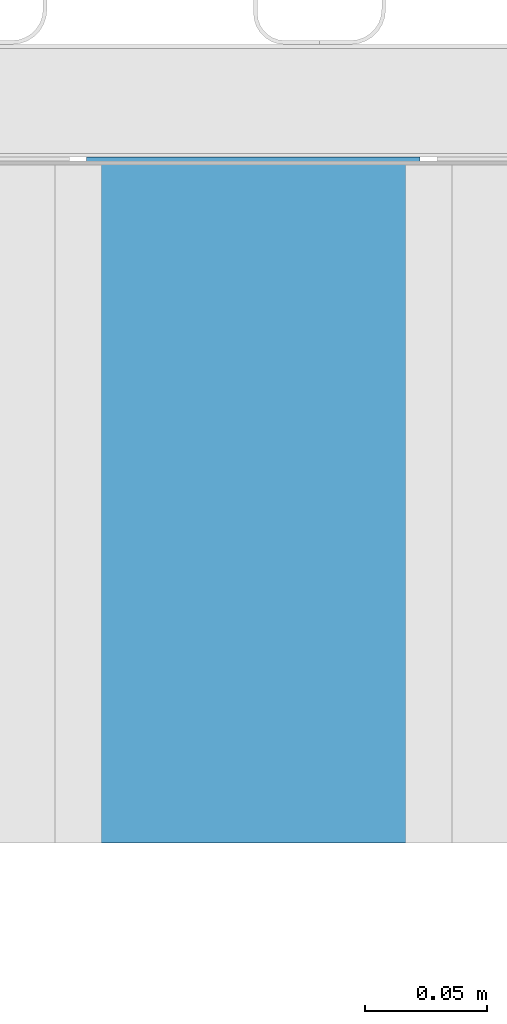
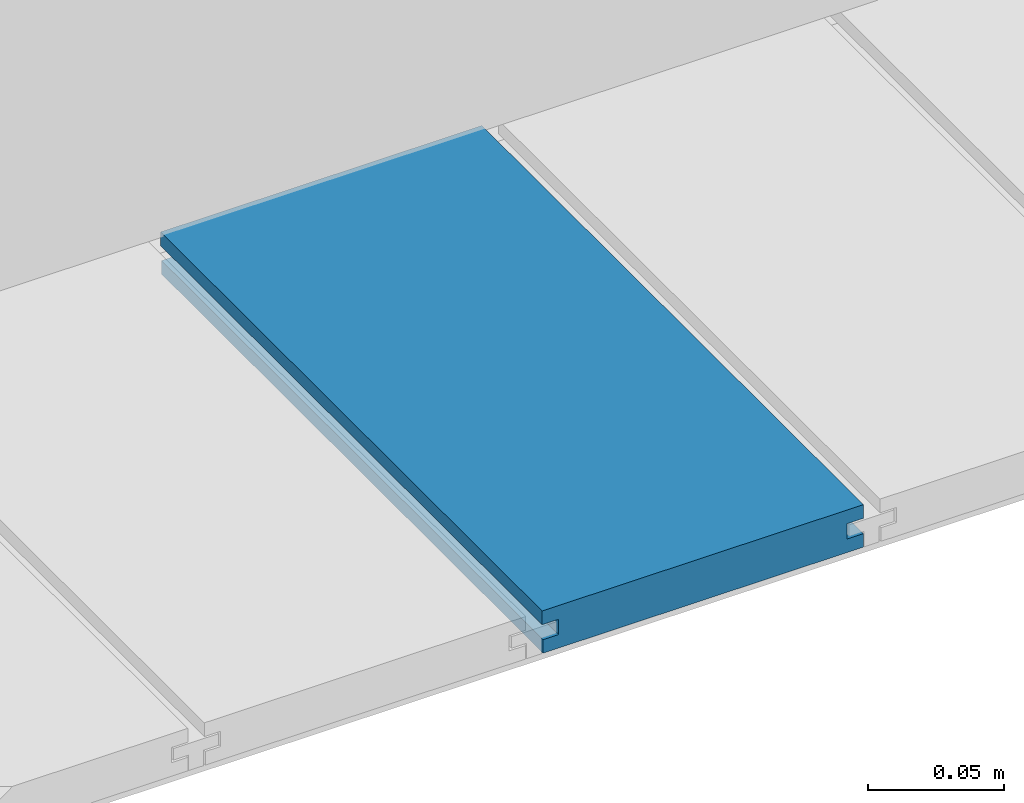
# One storey, part 13 of 33: 1 wall.
"""IFC4 building model written with IfcOpenShell, lengths in feet."""

from ifc_helpers import new_model, entity, si_unit, converted_unit, derived_unit, direction, frame, origin, place, context, subcontext, project, spatial, material, type_object, element, save


model = new_model("IFC4")

# Units and contexts
model_context = context("Model", 3, precision=0.0001, world=origin(), true_north=direction((6.12303176911189e-17, 1.0)))
body_context = subcontext(model_context, "Body", "Model", "MODEL_VIEW")
ifc_project = project(units=[converted_unit("LENGTHUNIT", "FOOT", entity("IfcRatioMeasure", 0.3048), si_unit("LENGTHUNIT", "METRE"), dimensions=[1, 0, 0, 0, 0, 0, 0]), converted_unit("AREAUNIT", "SQUARE FOOT", entity("IfcRatioMeasure", 0.09290304), si_unit("AREAUNIT", "SQUARE_METRE"), dimensions=[2, 0, 0, 0, 0, 0, 0]), converted_unit("VOLUMEUNIT", "CUBIC FOOT", entity("IfcRatioMeasure", 0.028316846592), si_unit("VOLUMEUNIT", "CUBIC_METRE"), dimensions=[3, 0, 0, 0, 0, 0, 0]), converted_unit("PLANEANGLEUNIT", "DEGREE", entity("IfcRatioMeasure", 0.0174532925199433), si_unit("PLANEANGLEUNIT", "RADIAN"), dimensions=[0, 0, 0, 0, 0, 0, 0]), si_unit("MASSUNIT", "GRAM", prefix="KILO"), derived_unit("MASSDENSITYUNIT", [(si_unit("MASSUNIT", "GRAM", prefix="KILO"), 1), (si_unit("LENGTHUNIT", "METRE"), -3)]), derived_unit("MOMENTOFINERTIAUNIT", [(si_unit("LENGTHUNIT", "METRE"), 4)]), si_unit("TIMEUNIT", "SECOND"), si_unit("FREQUENCYUNIT", "HERTZ"), si_unit("THERMODYNAMICTEMPERATUREUNIT", "DEGREE_CELSIUS"), derived_unit("THERMALTRANSMITTANCEUNIT", [(si_unit("MASSUNIT", "GRAM", prefix="KILO"), 1), (si_unit("THERMODYNAMICTEMPERATUREUNIT", "KELVIN"), -1), (si_unit("TIMEUNIT", "SECOND"), -3)]), derived_unit("VOLUMETRICFLOWRATEUNIT", [(si_unit("LENGTHUNIT", "METRE"), 3), (si_unit("TIMEUNIT", "SECOND"), -1)]), si_unit("ELECTRICCURRENTUNIT", "AMPERE"), si_unit("ELECTRICVOLTAGEUNIT", "VOLT"), si_unit("POWERUNIT", "WATT"), si_unit("FORCEUNIT", "NEWTON"), si_unit("ILLUMINANCEUNIT", "LUX"), si_unit("LUMINOUSFLUXUNIT", "LUMEN"), si_unit("LUMINOUSINTENSITYUNIT", "CANDELA"), derived_unit("USERDEFINED", [(si_unit("MASSUNIT", "GRAM", prefix="KILO"), -1), (si_unit("LENGTHUNIT", "METRE"), -2), (si_unit("TIMEUNIT", "SECOND"), 3), (si_unit("LUMINOUSFLUXUNIT", "LUMEN"), 1)]), derived_unit("LINEARVELOCITYUNIT", [(si_unit("LENGTHUNIT", "METRE"), 1), (si_unit("TIMEUNIT", "SECOND"), -1)]), si_unit("PRESSUREUNIT", "PASCAL"), derived_unit("USERDEFINED", [(si_unit("LENGTHUNIT", "METRE"), -2), (si_unit("MASSUNIT", "GRAM", prefix="KILO"), 1), (si_unit("TIMEUNIT", "SECOND"), -2)]), derived_unit("LINEARFORCEUNIT", [(si_unit("MASSUNIT", "GRAM", prefix="KILO"), 1), (si_unit("LENGTHUNIT", "METRE"), 1), (si_unit("TIMEUNIT", "SECOND"), -2), (si_unit("LENGTHUNIT", "METRE"), -1)]), derived_unit("PLANARFORCEUNIT", [(si_unit("MASSUNIT", "GRAM", prefix="KILO"), 1), (si_unit("LENGTHUNIT", "METRE"), 1), (si_unit("TIMEUNIT", "SECOND"), -2), (si_unit("LENGTHUNIT", "METRE"), -2)])], contexts=[model_context])

# Site, building, storey
site_placement = place(None, origin())
site = spatial("IfcSite", under=ifc_project, at=site_placement, CompositionType="ELEMENT")
building_placement = place(site_placement, origin())
building = spatial("IfcBuilding", under=site, at=building_placement, CompositionType="ELEMENT")
storey_placement = place(building_placement, frame((0.0, 0.0, 10.0)))
storey = spatial("IfcBuildingStorey", under=building, at=storey_placement, Name="2ND FLOOR", CompositionType="ELEMENT", Elevation=10.0000000000002)

# Wall
ifc_material = material(Name="COMPOSITE DECKING W/ HIDDEN FASTENERS", Category="Materials")
wall_type = type_object("IfcWallType", Name="Generic Models 727:Generic Models 1", PredefinedType="NOTDEFINED", material=ifc_material)
wall_placement = place(storey_placement, frame((1489.182591334, 3.04611392999271, 0.682902157150144), z_axis=(0.0, 0.0, 1.0), x_axis=(0.0, 1.0, 0.0)))
cartesian_point_1 = entity("IfcCartesianPoint", [0.919003339851618, -0.446740923891412, 0.0])
vertex_point_1 = entity("IfcVertexPoint", cartesian_point_1)
cartesian_point_2 = entity("IfcCartesianPoint", [0.919003339851621, -0.00132475379450625, 0.0])
vertex_point_2 = entity("IfcVertexPoint", cartesian_point_2)
ifc_direction_1 = entity("IfcDirection", [0.0, 1.0, 0.0])
edge_curve_1 = entity("IfcEdgeCurve", vertex_point_1, vertex_point_2, entity("IfcTrimmedCurve", entity("IfcLine", cartesian_point_1, entity("IfcVector", ifc_direction_1, 1.0)), [cartesian_point_1], [cartesian_point_2], True, "CARTESIAN"), True)
cartesian_point_3 = entity("IfcCartesianPoint", [0.919003339851621, -0.00132475379450625, 0.0198779960861479])
vertex_point_3 = entity("IfcVertexPoint", cartesian_point_3)
ifc_direction_2 = entity("IfcDirection", [0.0, 0.0, 1.0])
edge_curve_2 = entity("IfcEdgeCurve", vertex_point_2, vertex_point_3, entity("IfcTrimmedCurve", entity("IfcLine", cartesian_point_2, entity("IfcVector", ifc_direction_2, 1.0)), [cartesian_point_2], [cartesian_point_3], True, "CARTESIAN"), True)
cartesian_point_4 = entity("IfcCartesianPoint", [0.919003339851621, -0.0228400010807945, 0.0198779960861479])
vertex_point_4 = entity("IfcVertexPoint", cartesian_point_4)
ifc_direction_3 = entity("IfcDirection", [0.0, -1.0, 0.0])
edge_curve_3 = entity("IfcEdgeCurve", vertex_point_3, vertex_point_4, entity("IfcTrimmedCurve", entity("IfcLine", cartesian_point_3, entity("IfcVector", ifc_direction_3, 1.0)), [cartesian_point_3], [cartesian_point_4], True, "CARTESIAN"), True)
cartesian_point_5 = entity("IfcCartesianPoint", [0.919003339851621, -0.0228400010807945, 0.0422987663426522])
vertex_point_5 = entity("IfcVertexPoint", cartesian_point_5)
edge_curve_4 = entity("IfcEdgeCurve", vertex_point_4, vertex_point_5, entity("IfcTrimmedCurve", entity("IfcLine", cartesian_point_4, entity("IfcVector", ifc_direction_2, 1.0)), [cartesian_point_4], [cartesian_point_5], True, "CARTESIAN"), True)
cartesian_point_6 = entity("IfcCartesianPoint", [0.919003339851621, 0.0, 0.0422987663426522])
vertex_point_6 = entity("IfcVertexPoint", cartesian_point_6)
edge_curve_5 = entity("IfcEdgeCurve", vertex_point_5, vertex_point_6, entity("IfcTrimmedCurve", entity("IfcLine", cartesian_point_5, entity("IfcVector", ifc_direction_1, 1.0)), [cartesian_point_5], [cartesian_point_6], True, "CARTESIAN"), True)
cartesian_point_7 = entity("IfcCartesianPoint", [0.919003339851621, 0.0, 0.0625000000000551])
vertex_point_7 = entity("IfcVertexPoint", cartesian_point_7)
edge_curve_6 = entity("IfcEdgeCurve", vertex_point_6, vertex_point_7, entity("IfcTrimmedCurve", entity("IfcLine", cartesian_point_6, entity("IfcVector", ifc_direction_2, 1.0)), [cartesian_point_6], [cartesian_point_7], True, "CARTESIAN"), True)
cartesian_point_8 = entity("IfcCartesianPoint", [0.919003339851618, -0.446740923891639, 0.0625])
vertex_point_8 = entity("IfcVertexPoint", cartesian_point_8)
edge_curve_7 = entity("IfcEdgeCurve", vertex_point_7, vertex_point_8, entity("IfcTrimmedCurve", entity("IfcLine", cartesian_point_7, entity("IfcVector", ifc_direction_3, 1.0)), [cartesian_point_7], [cartesian_point_8], True, "CARTESIAN"), True)
cartesian_point_9 = entity("IfcCartesianPoint", [0.919003339851618, -0.446740923891639, 0.0422987663426522])
vertex_point_9 = entity("IfcVertexPoint", cartesian_point_9)
ifc_direction_4 = entity("IfcDirection", [0.0, 0.0, -1.0])
edge_curve_8 = entity("IfcEdgeCurve", vertex_point_8, vertex_point_9, entity("IfcTrimmedCurve", entity("IfcLine", cartesian_point_8, entity("IfcVector", ifc_direction_4, 1.0)), [cartesian_point_8], [cartesian_point_9], True, "CARTESIAN"), True)
cartesian_point_10 = entity("IfcCartesianPoint", [0.919003339851618, -0.423900922810617, 0.0422987663426522])
vertex_point_10 = entity("IfcVertexPoint", cartesian_point_10)
edge_curve_9 = entity("IfcEdgeCurve", vertex_point_9, vertex_point_10, entity("IfcTrimmedCurve", entity("IfcLine", cartesian_point_9, entity("IfcVector", ifc_direction_1, 1.0)), [cartesian_point_9], [cartesian_point_10], True, "CARTESIAN"), True)
cartesian_point_11 = entity("IfcCartesianPoint", [0.919003339851618, -0.423900922810617, 0.0198779960861479])
vertex_point_11 = entity("IfcVertexPoint", cartesian_point_11)
edge_curve_10 = entity("IfcEdgeCurve", vertex_point_10, vertex_point_11, entity("IfcTrimmedCurve", entity("IfcLine", cartesian_point_10, entity("IfcVector", ifc_direction_4, 1.0)), [cartesian_point_10], [cartesian_point_11], True, "CARTESIAN"), True)
cartesian_point_12 = entity("IfcCartesianPoint", [0.919003339851618, -0.446740923891412, 0.0198779960861479])
vertex_point_12 = entity("IfcVertexPoint", cartesian_point_12)
edge_curve_11 = entity("IfcEdgeCurve", vertex_point_11, vertex_point_12, entity("IfcTrimmedCurve", entity("IfcLine", cartesian_point_11, entity("IfcVector", ifc_direction_3, 1.0)), [cartesian_point_11], [cartesian_point_12], True, "CARTESIAN"), True)
edge_curve_12 = entity("IfcEdgeCurve", vertex_point_12, vertex_point_1, entity("IfcTrimmedCurve", entity("IfcLine", cartesian_point_12, entity("IfcVector", ifc_direction_4, 1.0)), [cartesian_point_12], [cartesian_point_1], True, "CARTESIAN"), True)
ifc_direction_5 = entity("IfcDirection", [1.0, 0.0, 0.0])
cartesian_point_13 = entity("IfcCartesianPoint", [0.0, -0.446740923891412, 0.0])
vertex_point_13 = entity("IfcVertexPoint", cartesian_point_13)
cartesian_point_14 = entity("IfcCartesianPoint", [0.0, -0.446740923891412, 0.0198779960861479])
vertex_point_14 = entity("IfcVertexPoint", cartesian_point_14)
edge_curve_13 = entity("IfcEdgeCurve", vertex_point_13, vertex_point_14, entity("IfcTrimmedCurve", entity("IfcLine", cartesian_point_13, entity("IfcVector", ifc_direction_2, 1.0)), [cartesian_point_13], [cartesian_point_14], True, "CARTESIAN"), True)
cartesian_point_15 = entity("IfcCartesianPoint", [0.0, -0.423900922810617, 0.0198779960861479])
vertex_point_15 = entity("IfcVertexPoint", cartesian_point_15)
edge_curve_14 = entity("IfcEdgeCurve", vertex_point_14, vertex_point_15, entity("IfcTrimmedCurve", entity("IfcLine", cartesian_point_14, entity("IfcVector", ifc_direction_1, 1.0)), [cartesian_point_14], [cartesian_point_15], True, "CARTESIAN"), True)
cartesian_point_16 = entity("IfcCartesianPoint", [0.0, -0.423900922810617, 0.0422987663426522])
vertex_point_16 = entity("IfcVertexPoint", cartesian_point_16)
edge_curve_15 = entity("IfcEdgeCurve", vertex_point_15, vertex_point_16, entity("IfcTrimmedCurve", entity("IfcLine", cartesian_point_15, entity("IfcVector", ifc_direction_2, 1.0)), [cartesian_point_15], [cartesian_point_16], True, "CARTESIAN"), True)
cartesian_point_17 = entity("IfcCartesianPoint", [0.0, -0.446740923891639, 0.0422987663426522])
vertex_point_17 = entity("IfcVertexPoint", cartesian_point_17)
edge_curve_16 = entity("IfcEdgeCurve", vertex_point_16, vertex_point_17, entity("IfcTrimmedCurve", entity("IfcLine", cartesian_point_16, entity("IfcVector", ifc_direction_3, 1.0)), [cartesian_point_16], [cartesian_point_17], True, "CARTESIAN"), True)
cartesian_point_18 = entity("IfcCartesianPoint", [0.0, -0.446740923891639, 0.0625])
vertex_point_18 = entity("IfcVertexPoint", cartesian_point_18)
edge_curve_17 = entity("IfcEdgeCurve", vertex_point_17, vertex_point_18, entity("IfcTrimmedCurve", entity("IfcLine", cartesian_point_17, entity("IfcVector", ifc_direction_2, 1.0)), [cartesian_point_17], [cartesian_point_18], True, "CARTESIAN"), True)
cartesian_point_19 = entity("IfcCartesianPoint", [0.0, 0.0, 0.0625000000000551])
vertex_point_19 = entity("IfcVertexPoint", cartesian_point_19)
edge_curve_18 = entity("IfcEdgeCurve", vertex_point_18, vertex_point_19, entity("IfcTrimmedCurve", entity("IfcLine", cartesian_point_18, entity("IfcVector", ifc_direction_1, 1.0)), [cartesian_point_18], [cartesian_point_19], True, "CARTESIAN"), True)
cartesian_point_20 = entity("IfcCartesianPoint", [0.0, 0.0, 0.0422987663426522])
vertex_point_20 = entity("IfcVertexPoint", cartesian_point_20)
edge_curve_19 = entity("IfcEdgeCurve", vertex_point_19, vertex_point_20, entity("IfcTrimmedCurve", entity("IfcLine", cartesian_point_19, entity("IfcVector", ifc_direction_4, 1.0)), [cartesian_point_19], [cartesian_point_20], True, "CARTESIAN"), True)
cartesian_point_21 = entity("IfcCartesianPoint", [0.0, -0.0228400010807945, 0.0422987663426522])
vertex_point_21 = entity("IfcVertexPoint", cartesian_point_21)
edge_curve_20 = entity("IfcEdgeCurve", vertex_point_20, vertex_point_21, entity("IfcTrimmedCurve", entity("IfcLine", cartesian_point_20, entity("IfcVector", ifc_direction_3, 1.0)), [cartesian_point_20], [cartesian_point_21], True, "CARTESIAN"), True)
cartesian_point_22 = entity("IfcCartesianPoint", [0.0, -0.0228400010807945, 0.0198779960861479])
vertex_point_22 = entity("IfcVertexPoint", cartesian_point_22)
edge_curve_21 = entity("IfcEdgeCurve", vertex_point_21, vertex_point_22, entity("IfcTrimmedCurve", entity("IfcLine", cartesian_point_21, entity("IfcVector", ifc_direction_4, 1.0)), [cartesian_point_21], [cartesian_point_22], True, "CARTESIAN"), True)
cartesian_point_23 = entity("IfcCartesianPoint", [0.0, -0.00132475379450625, 0.0198779960861479])
vertex_point_23 = entity("IfcVertexPoint", cartesian_point_23)
edge_curve_22 = entity("IfcEdgeCurve", vertex_point_22, vertex_point_23, entity("IfcTrimmedCurve", entity("IfcLine", cartesian_point_22, entity("IfcVector", ifc_direction_1, 1.0)), [cartesian_point_22], [cartesian_point_23], True, "CARTESIAN"), True)
cartesian_point_24 = entity("IfcCartesianPoint", [0.0, -0.00132475379450625, 0.0])
vertex_point_24 = entity("IfcVertexPoint", cartesian_point_24)
edge_curve_23 = entity("IfcEdgeCurve", vertex_point_23, vertex_point_24, entity("IfcTrimmedCurve", entity("IfcLine", cartesian_point_23, entity("IfcVector", ifc_direction_4, 1.0)), [cartesian_point_23], [cartesian_point_24], True, "CARTESIAN"), True)
edge_curve_24 = entity("IfcEdgeCurve", vertex_point_24, vertex_point_13, entity("IfcTrimmedCurve", entity("IfcLine", cartesian_point_24, entity("IfcVector", ifc_direction_3, 1.0)), [cartesian_point_24], [cartesian_point_13], True, "CARTESIAN"), True)
ifc_direction_6 = entity("IfcDirection", [-1.0, 0.0, 0.0])
edge_curve_25 = entity("IfcEdgeCurve", vertex_point_13, vertex_point_1, entity("IfcTrimmedCurve", entity("IfcLine", cartesian_point_13, entity("IfcVector", ifc_direction_5, 1.0)), [cartesian_point_13], [cartesian_point_1], True, "CARTESIAN"), True)
edge_curve_26 = entity("IfcEdgeCurve", vertex_point_12, vertex_point_14, entity("IfcTrimmedCurve", entity("IfcLine", cartesian_point_14, entity("IfcVector", ifc_direction_6, 1.0)), [cartesian_point_12], [cartesian_point_14], True, "CARTESIAN"), True)
edge_curve_27 = entity("IfcEdgeCurve", vertex_point_18, vertex_point_8, entity("IfcTrimmedCurve", entity("IfcLine", cartesian_point_18, entity("IfcVector", ifc_direction_5, 1.0)), [cartesian_point_18], [cartesian_point_8], True, "CARTESIAN"), True)
edge_curve_28 = entity("IfcEdgeCurve", vertex_point_7, vertex_point_19, entity("IfcTrimmedCurve", entity("IfcLine", cartesian_point_19, entity("IfcVector", ifc_direction_6, 1.0)), [cartesian_point_7], [cartesian_point_19], True, "CARTESIAN"), True)
edge_curve_29 = entity("IfcEdgeCurve", vertex_point_6, vertex_point_20, entity("IfcTrimmedCurve", entity("IfcLine", cartesian_point_20, entity("IfcVector", ifc_direction_6, 1.0)), [cartesian_point_6], [cartesian_point_20], True, "CARTESIAN"), True)
edge_curve_30 = entity("IfcEdgeCurve", vertex_point_24, vertex_point_2, entity("IfcTrimmedCurve", entity("IfcLine", cartesian_point_24, entity("IfcVector", ifc_direction_5, 1.0)), [cartesian_point_24], [cartesian_point_2], True, "CARTESIAN"), True)
edge_curve_31 = entity("IfcEdgeCurve", vertex_point_17, vertex_point_9, entity("IfcTrimmedCurve", entity("IfcLine", cartesian_point_17, entity("IfcVector", ifc_direction_5, 1.0)), [cartesian_point_17], [cartesian_point_9], True, "CARTESIAN"), True)
edge_curve_32 = entity("IfcEdgeCurve", vertex_point_5, vertex_point_21, entity("IfcTrimmedCurve", entity("IfcLine", cartesian_point_21, entity("IfcVector", ifc_direction_6, 1.0)), [cartesian_point_5], [cartesian_point_21], True, "CARTESIAN"), True)
edge_curve_33 = entity("IfcEdgeCurve", vertex_point_4, vertex_point_22, entity("IfcTrimmedCurve", entity("IfcLine", cartesian_point_22, entity("IfcVector", ifc_direction_6, 1.0)), [cartesian_point_4], [cartesian_point_22], True, "CARTESIAN"), True)
edge_curve_34 = entity("IfcEdgeCurve", vertex_point_3, vertex_point_23, entity("IfcTrimmedCurve", entity("IfcLine", cartesian_point_23, entity("IfcVector", ifc_direction_6, 1.0)), [cartesian_point_3], [cartesian_point_23], True, "CARTESIAN"), True)
edge_curve_35 = entity("IfcEdgeCurve", vertex_point_11, vertex_point_15, entity("IfcTrimmedCurve", entity("IfcLine", cartesian_point_15, entity("IfcVector", ifc_direction_6, 1.0)), [cartesian_point_11], [cartesian_point_15], True, "CARTESIAN"), True)
edge_curve_36 = entity("IfcEdgeCurve", vertex_point_10, vertex_point_16, entity("IfcTrimmedCurve", entity("IfcLine", cartesian_point_16, entity("IfcVector", ifc_direction_6, 1.0)), [cartesian_point_10], [cartesian_point_16], True, "CARTESIAN"), True)
element("IfcWall", 1, at=wall_placement, inside=storey, type_object=wall_type, material=ifc_material, Name="Generic Models 727:Generic Models 1", ObjectType="Generic Models 727:Generic Models 1", PredefinedType="NOTDEFINED", context=body_context, shape_type="AdvancedBrep", body=[
    entity("IfcAdvancedBrep", entity("IfcClosedShell", [entity("IfcAdvancedFace", [entity("IfcFaceOuterBound", entity("IfcEdgeLoop", [entity("IfcOrientedEdge", None, None, edge_curve_1, True), entity("IfcOrientedEdge", None, None, edge_curve_2, True), entity("IfcOrientedEdge", None, None, edge_curve_3, True), entity("IfcOrientedEdge", None, None, edge_curve_4, True), entity("IfcOrientedEdge", None, None, edge_curve_5, True), entity("IfcOrientedEdge", None, None, edge_curve_6, True), entity("IfcOrientedEdge", None, None, edge_curve_7, True), entity("IfcOrientedEdge", None, None, edge_curve_8, True), entity("IfcOrientedEdge", None, None, edge_curve_9, True), entity("IfcOrientedEdge", None, None, edge_curve_10, True), entity("IfcOrientedEdge", None, None, edge_curve_11, True), entity("IfcOrientedEdge", None, None, edge_curve_12, True)]), True)], entity("IfcPlane", entity("IfcAxis2Placement3D", entity("IfcCartesianPoint", [0.919003339851618, -0.446740923891412, -0.0208333333328241]), ifc_direction_5, ifc_direction_4)), True), entity("IfcAdvancedFace", [entity("IfcFaceOuterBound", entity("IfcEdgeLoop", [entity("IfcOrientedEdge", None, None, edge_curve_13, True), entity("IfcOrientedEdge", None, None, edge_curve_14, True), entity("IfcOrientedEdge", None, None, edge_curve_15, True), entity("IfcOrientedEdge", None, None, edge_curve_16, True), entity("IfcOrientedEdge", None, None, edge_curve_17, True), entity("IfcOrientedEdge", None, None, edge_curve_18, True), entity("IfcOrientedEdge", None, None, edge_curve_19, True), entity("IfcOrientedEdge", None, None, edge_curve_20, True), entity("IfcOrientedEdge", None, None, edge_curve_21, True), entity("IfcOrientedEdge", None, None, edge_curve_22, True), entity("IfcOrientedEdge", None, None, edge_curve_23, True), entity("IfcOrientedEdge", None, None, edge_curve_24, True)]), True)], entity("IfcPlane", entity("IfcAxis2Placement3D", entity("IfcCartesianPoint", [0.0, -0.446740923891412, -0.0208333333328241]), ifc_direction_6, ifc_direction_2)), True), entity("IfcAdvancedFace", [entity("IfcFaceOuterBound", entity("IfcEdgeLoop", [entity("IfcOrientedEdge", None, None, edge_curve_13, False), entity("IfcOrientedEdge", None, None, edge_curve_25, True), entity("IfcOrientedEdge", None, None, edge_curve_12, False), entity("IfcOrientedEdge", None, None, edge_curve_26, True)]), True)], entity("IfcPlane", entity("IfcAxis2Placement3D", cartesian_point_13, ifc_direction_3, ifc_direction_5)), True), entity("IfcAdvancedFace", [entity("IfcFaceOuterBound", entity("IfcEdgeLoop", [entity("IfcOrientedEdge", None, None, edge_curve_18, False), entity("IfcOrientedEdge", None, None, edge_curve_27, True), entity("IfcOrientedEdge", None, None, edge_curve_7, False), entity("IfcOrientedEdge", None, None, edge_curve_28, True)]), True)], entity("IfcPlane", entity("IfcAxis2Placement3D", cartesian_point_18, ifc_direction_2, ifc_direction_5)), True), entity("IfcAdvancedFace", [entity("IfcFaceOuterBound", entity("IfcEdgeLoop", [entity("IfcOrientedEdge", None, None, edge_curve_19, False), entity("IfcOrientedEdge", None, None, edge_curve_28, False), entity("IfcOrientedEdge", None, None, edge_curve_6, False), entity("IfcOrientedEdge", None, None, edge_curve_29, True)]), True)], entity("IfcPlane", entity("IfcAxis2Placement3D", cartesian_point_19, ifc_direction_1, ifc_direction_5)), True), entity("IfcAdvancedFace", [entity("IfcFaceOuterBound", entity("IfcEdgeLoop", [entity("IfcOrientedEdge", None, None, edge_curve_24, False), entity("IfcOrientedEdge", None, None, edge_curve_30, True), entity("IfcOrientedEdge", None, None, edge_curve_1, False), entity("IfcOrientedEdge", None, None, edge_curve_25, False)]), True)], entity("IfcPlane", entity("IfcAxis2Placement3D", cartesian_point_24, ifc_direction_4, ifc_direction_5)), True), entity("IfcAdvancedFace", [entity("IfcFaceOuterBound", entity("IfcEdgeLoop", [entity("IfcOrientedEdge", None, None, edge_curve_17, False), entity("IfcOrientedEdge", None, None, edge_curve_31, True), entity("IfcOrientedEdge", None, None, edge_curve_8, False), entity("IfcOrientedEdge", None, None, edge_curve_27, False)]), True)], entity("IfcPlane", entity("IfcAxis2Placement3D", cartesian_point_17, ifc_direction_3, ifc_direction_5)), True), entity("IfcAdvancedFace", [entity("IfcFaceOuterBound", entity("IfcEdgeLoop", [entity("IfcOrientedEdge", None, None, edge_curve_20, False), entity("IfcOrientedEdge", None, None, edge_curve_29, False), entity("IfcOrientedEdge", None, None, edge_curve_5, False), entity("IfcOrientedEdge", None, None, edge_curve_32, True)]), True)], entity("IfcPlane", entity("IfcAxis2Placement3D", cartesian_point_20, ifc_direction_4, ifc_direction_5)), True), entity("IfcAdvancedFace", [entity("IfcFaceOuterBound", entity("IfcEdgeLoop", [entity("IfcOrientedEdge", None, None, edge_curve_21, False), entity("IfcOrientedEdge", None, None, edge_curve_32, False), entity("IfcOrientedEdge", None, None, edge_curve_4, False), entity("IfcOrientedEdge", None, None, edge_curve_33, True)]), True)], entity("IfcPlane", entity("IfcAxis2Placement3D", cartesian_point_21, ifc_direction_1, ifc_direction_5)), True), entity("IfcAdvancedFace", [entity("IfcFaceOuterBound", entity("IfcEdgeLoop", [entity("IfcOrientedEdge", None, None, edge_curve_22, False), entity("IfcOrientedEdge", None, None, edge_curve_33, False), entity("IfcOrientedEdge", None, None, edge_curve_3, False), entity("IfcOrientedEdge", None, None, edge_curve_34, True)]), True)], entity("IfcPlane", entity("IfcAxis2Placement3D", cartesian_point_22, ifc_direction_2, ifc_direction_5)), True), entity("IfcAdvancedFace", [entity("IfcFaceOuterBound", entity("IfcEdgeLoop", [entity("IfcOrientedEdge", None, None, edge_curve_23, False), entity("IfcOrientedEdge", None, None, edge_curve_34, False), entity("IfcOrientedEdge", None, None, edge_curve_2, False), entity("IfcOrientedEdge", None, None, edge_curve_30, False)]), True)], entity("IfcPlane", entity("IfcAxis2Placement3D", cartesian_point_23, ifc_direction_1, ifc_direction_5)), True), entity("IfcAdvancedFace", [entity("IfcFaceOuterBound", entity("IfcEdgeLoop", [entity("IfcOrientedEdge", None, None, edge_curve_14, False), entity("IfcOrientedEdge", None, None, edge_curve_26, False), entity("IfcOrientedEdge", None, None, edge_curve_11, False), entity("IfcOrientedEdge", None, None, edge_curve_35, True)]), True)], entity("IfcPlane", entity("IfcAxis2Placement3D", cartesian_point_14, ifc_direction_2, ifc_direction_5)), True), entity("IfcAdvancedFace", [entity("IfcFaceOuterBound", entity("IfcEdgeLoop", [entity("IfcOrientedEdge", None, None, edge_curve_15, False), entity("IfcOrientedEdge", None, None, edge_curve_35, False), entity("IfcOrientedEdge", None, None, edge_curve_10, False), entity("IfcOrientedEdge", None, None, edge_curve_36, True)]), True)], entity("IfcPlane", entity("IfcAxis2Placement3D", cartesian_point_15, ifc_direction_3, ifc_direction_5)), True), entity("IfcAdvancedFace", [entity("IfcFaceOuterBound", entity("IfcEdgeLoop", [entity("IfcOrientedEdge", None, None, edge_curve_16, False), entity("IfcOrientedEdge", None, None, edge_curve_36, False), entity("IfcOrientedEdge", None, None, edge_curve_9, False), entity("IfcOrientedEdge", None, None, edge_curve_31, False)]), True)], entity("IfcPlane", entity("IfcAxis2Placement3D", cartesian_point_16, ifc_direction_4, ifc_direction_5)), True)])),
])

save(model, "model.ifc")
